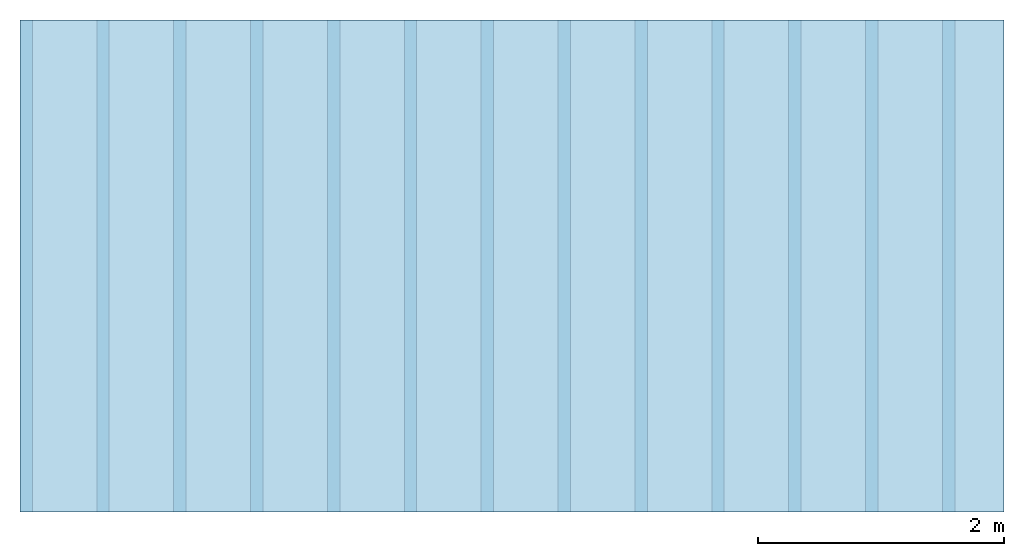
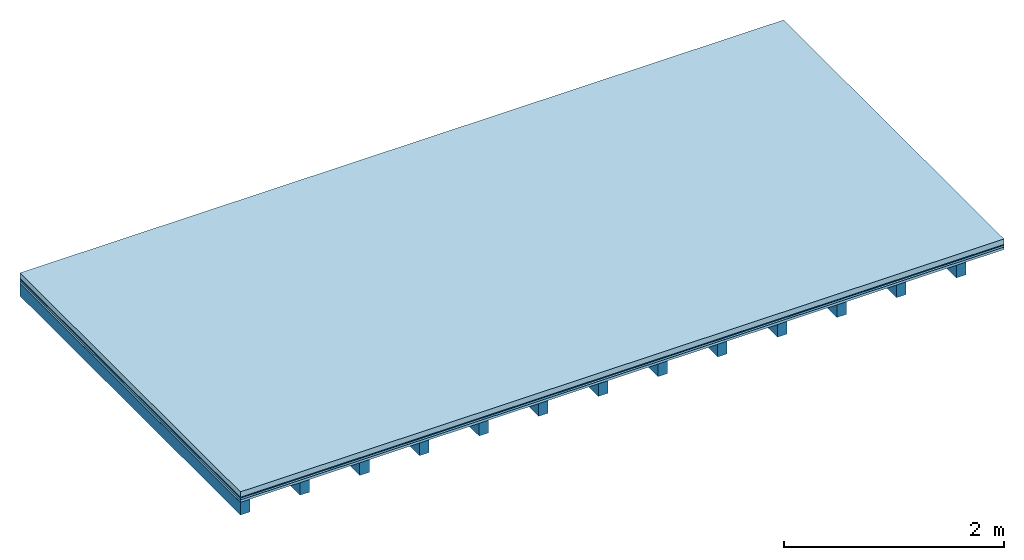
# One storey: 4 plates, 1 member, 1 element without a shape of its own.
"""IFC4 building model written with IfcOpenShell, lengths in metres."""

from ifc_helpers import new_model, si_unit, derived_unit, direction, frame, frame_2d, origin, origin_with_axes, place, context, project, spatial, rectangle, extrude, material, layer, layer_set, type_object, element, aggregate, save


model = new_model("IFC4")

# Units and contexts
plan_context = context("Plan", 3, precision=1e-05, world=origin(), true_north=direction((0.0, 1.0)))
model_context = context("Model", 3, precision=1e-05, world=origin(), true_north=direction((0.0, 1.0)))
ifc_project = project(units=[si_unit("LENGTHUNIT", "METRE"), derived_unit("SOUNDPRESSUREUNIT", [(si_unit("PRESSUREUNIT", "PASCAL", prefix="MICRO"), 0)]), si_unit("ENERGYUNIT", "JOULE", prefix="MEGA"), si_unit("MASSUNIT", "GRAM", prefix="KILO"), derived_unit("THERMALTRANSMITTANCEUNIT", [(si_unit("POWERUNIT", "WATT"), 1), (si_unit("AREAUNIT", "SQUARE_METRE"), -1), (si_unit("THERMODYNAMICTEMPERATUREUNIT", "KELVIN"), -1)]), derived_unit("AREADENSITYUNIT", [(si_unit("MASSUNIT", "GRAM", prefix="KILO"), 1), (si_unit("AREAUNIT", "SQUARE_METRE"), -1)]), derived_unit("USERDEFINED", [(si_unit("ENERGYUNIT", "JOULE", prefix="MEGA"), 1), (si_unit("AREAUNIT", "SQUARE_METRE"), -1)])], contexts=[plan_context, model_context])

# Site, building, storey
site = spatial("IfcSite", under=ifc_project)
building_placement = place(None, origin())
building = spatial("IfcBuilding", under=site, at=building_placement)
storey_placement = place(building_placement, origin())
storey = spatial("IfcBuildingStorey", under=building, at=storey_placement)

# Slab, member, plates
ifc_material_1 = material(Name="clay", Category="02.004")
ifc_layer_1 = layer(ifc_material_1, 0.06, Name="Use and protection layer 2")
ifc_material_2 = material(Name="Protective layer", Category="09.007")
ifc_layer_2 = layer(ifc_material_2, 0.01, Name="Use and protection layer 1")
ifc_material_3 = material(Name="Bituminous", Category="09.003")
ifc_layer_3 = layer(ifc_material_3, 0.02, Name="Seal")
ifc_material_4 = material(Name="3-layer panels", Category="07.001")
ifc_layer_4 = layer(ifc_material_4, 0.027, Name="above 2nd layer")
ifc_material_5 = material(Name="no composite action")
ifc_layer_5 = layer(ifc_material_5, 0.0, Name="Bond")
ifc_layer_6 = layer(None, 0.14, Name="Support")
ifc_layer_set = layer_set([ifc_layer_1, ifc_layer_2, ifc_layer_3, ifc_layer_4, ifc_layer_5, ifc_layer_6])
slab_type = type_object("IfcSlabType", Name="F0093", PredefinedType="NOTDEFINED", material=ifc_layer_set)
slab_placement = place(None, frame((0.0, 0.0, 0.0), z_axis=(0.0, 0.0, -1.0), x_axis=(1.0, 0.0, 0.0)))
slab = element("IfcSlab", 1, at=slab_placement, inside=storey, type_object=slab_type, material=ifc_layer_set, Name="Slab #1")
ifc_material_6 = material()
member_placement = place(slab_placement, origin())
member = element("IfcMember", 2, at=member_placement, material=ifc_material_6, Name="Support", context=plan_context, shape_type="SweptSolid", body=[
    extrude(rectangle(XDim=0.1, YDim=0.14, at=frame_2d((0.05, 0.07), x_axis=(1.0, 0.0))), frame((0.0, 4.0, 0.117), z_axis=(0.0, -1.0, 0.0), x_axis=(1.0, 0.0, 0.0)), (0.0, 0.0, 1.0), 4.0),
    extrude(rectangle(XDim=0.1, YDim=0.14, at=frame_2d((0.05, 0.07), x_axis=(1.0, 0.0))), frame((0.625, 4.0, 0.117), z_axis=(0.0, -1.0, 0.0), x_axis=(1.0, 0.0, 0.0)), (0.0, 0.0, 1.0), 4.0),
    extrude(rectangle(XDim=0.1, YDim=0.14, at=frame_2d((0.05, 0.07), x_axis=(1.0, 0.0))), frame((1.25, 4.0, 0.117), z_axis=(0.0, -1.0, 0.0), x_axis=(1.0, 0.0, 0.0)), (0.0, 0.0, 1.0), 4.0),
    extrude(rectangle(XDim=0.1, YDim=0.14, at=frame_2d((0.05, 0.07), x_axis=(1.0, 0.0))), frame((1.875, 4.0, 0.117), z_axis=(0.0, -1.0, 0.0), x_axis=(1.0, 0.0, 0.0)), (0.0, 0.0, 1.0), 4.0),
    extrude(rectangle(XDim=0.1, YDim=0.14, at=frame_2d((0.05, 0.07), x_axis=(1.0, 0.0))), frame((2.5, 4.0, 0.117), z_axis=(0.0, -1.0, 0.0), x_axis=(1.0, 0.0, 0.0)), (0.0, 0.0, 1.0), 4.0),
    extrude(rectangle(XDim=0.1, YDim=0.14, at=frame_2d((0.05, 0.07), x_axis=(1.0, 0.0))), frame((3.125, 4.0, 0.117), z_axis=(0.0, -1.0, 0.0), x_axis=(1.0, 0.0, 0.0)), (0.0, 0.0, 1.0), 4.0),
    extrude(rectangle(XDim=0.1, YDim=0.14, at=frame_2d((0.05, 0.07), x_axis=(1.0, 0.0))), frame((3.75, 4.0, 0.117), z_axis=(0.0, -1.0, 0.0), x_axis=(1.0, 0.0, 0.0)), (0.0, 0.0, 1.0), 4.0),
    extrude(rectangle(XDim=0.1, YDim=0.14, at=frame_2d((0.05, 0.07), x_axis=(1.0, 0.0))), frame((4.375, 4.0, 0.117), z_axis=(0.0, -1.0, 0.0), x_axis=(1.0, 0.0, 0.0)), (0.0, 0.0, 1.0), 4.0),
    extrude(rectangle(XDim=0.1, YDim=0.14, at=frame_2d((0.05, 0.07), x_axis=(1.0, 0.0))), frame((5.0, 4.0, 0.117), z_axis=(0.0, -1.0, 0.0), x_axis=(1.0, 0.0, 0.0)), (0.0, 0.0, 1.0), 4.0),
    extrude(rectangle(XDim=0.1, YDim=0.14, at=frame_2d((0.05, 0.07), x_axis=(1.0, 0.0))), frame((5.625, 4.0, 0.117), z_axis=(0.0, -1.0, 0.0), x_axis=(1.0, 0.0, 0.0)), (0.0, 0.0, 1.0), 4.0),
    extrude(rectangle(XDim=0.1, YDim=0.14, at=frame_2d((0.05, 0.07), x_axis=(1.0, 0.0))), frame((6.25, 4.0, 0.117), z_axis=(0.0, -1.0, 0.0), x_axis=(1.0, 0.0, 0.0)), (0.0, 0.0, 1.0), 4.0),
    extrude(rectangle(XDim=0.1, YDim=0.14, at=frame_2d((0.05, 0.07), x_axis=(1.0, 0.0))), frame((6.875, 4.0, 0.117), z_axis=(0.0, -1.0, 0.0), x_axis=(1.0, 0.0, 0.0)), (0.0, 0.0, 1.0), 4.0),
    extrude(rectangle(XDim=0.1, YDim=0.14, at=frame_2d((0.05, 0.07), x_axis=(1.0, 0.0))), frame((7.5, 4.0, 0.117), z_axis=(0.0, -1.0, 0.0), x_axis=(1.0, 0.0, 0.0)), (0.0, 0.0, 1.0), 4.0),
])
plate_1_placement = place(slab_placement, origin())
plate_1 = element("IfcPlate", 3, at=plate_1_placement, material=ifc_material_1, Name="Use and protection layer 2", context=plan_context, shape_type="SweptSolid", body=[
    extrude(rectangle(XDim=8.0, YDim=4.0, at=frame_2d((4.0, 2.0), x_axis=(1.0, 0.0))), origin_with_axes(), (0.0, 0.0, 1.0), 0.06),
])
plate_2_placement = place(slab_placement, origin())
plate_2 = element("IfcPlate", 4, at=plate_2_placement, material=ifc_material_2, Name="Use and protection layer 1", context=plan_context, shape_type="SweptSolid", body=[
    extrude(rectangle(XDim=8.0, YDim=4.0, at=frame_2d((4.0, 2.0), x_axis=(1.0, 0.0))), frame((0.0, 0.0, 0.06), z_axis=(0.0, 0.0, 1.0), x_axis=(1.0, 0.0, 0.0)), (0.0, 0.0, 1.0), 0.01),
])
plate_3_placement = place(slab_placement, origin())
plate_3 = element("IfcPlate", 5, at=plate_3_placement, material=ifc_material_3, Name="Seal", context=plan_context, shape_type="SweptSolid", body=[
    extrude(rectangle(XDim=8.0, YDim=4.0, at=frame_2d((4.0, 2.0), x_axis=(1.0, 0.0))), frame((0.0, 0.0, 0.07), z_axis=(0.0, 0.0, 1.0), x_axis=(1.0, 0.0, 0.0)), (0.0, 0.0, 1.0), 0.02),
])
plate_4_placement = place(slab_placement, origin())
plate_4 = element("IfcPlate", 6, at=plate_4_placement, material=ifc_material_4, Name="above 2nd layer", context=plan_context, shape_type="SweptSolid", body=[
    extrude(rectangle(XDim=8.0, YDim=4.0, at=frame_2d((4.0, 2.0), x_axis=(1.0, 0.0))), frame((0.0, 0.0, 0.09), z_axis=(0.0, 0.0, 1.0), x_axis=(1.0, 0.0, 0.0)), (0.0, 0.0, 1.0), 0.027),
])
aggregate(slab, [plate_1, plate_2, plate_3, plate_4, member])

save(model, "model.ifc")
